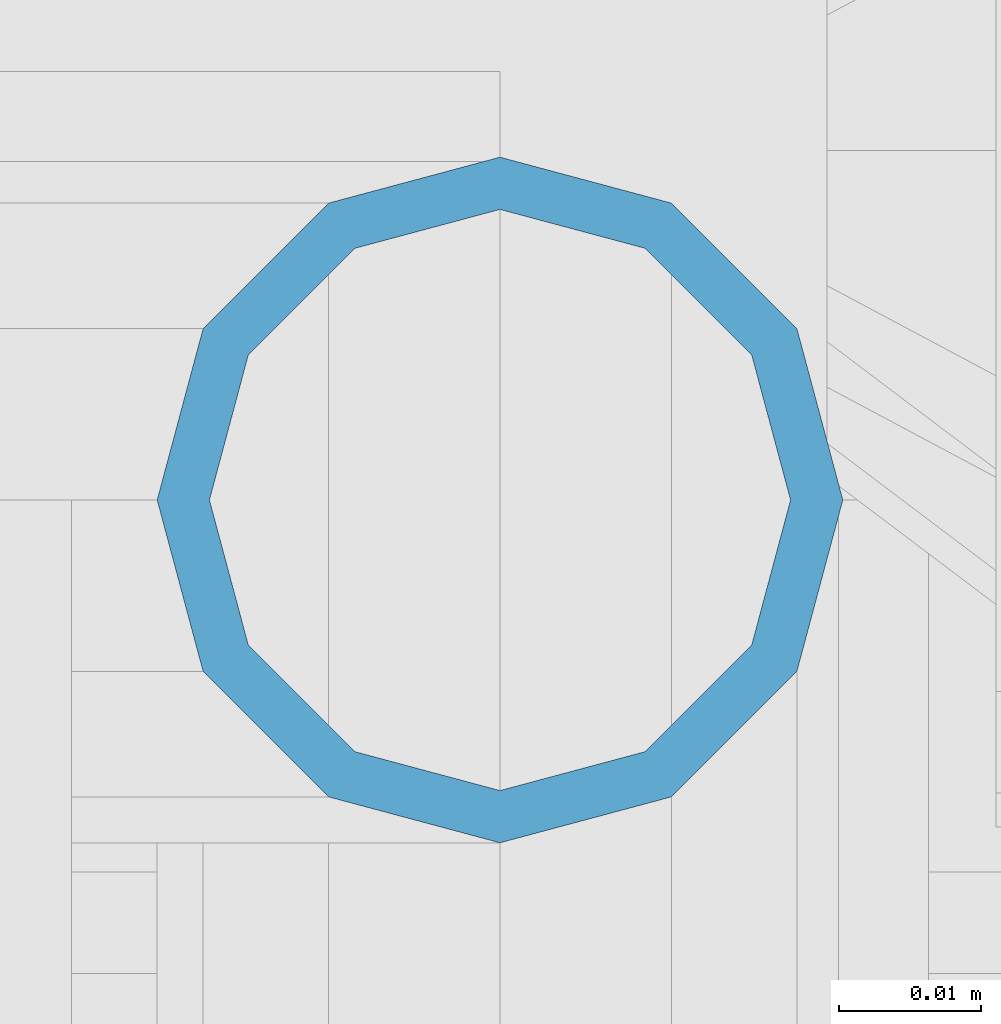
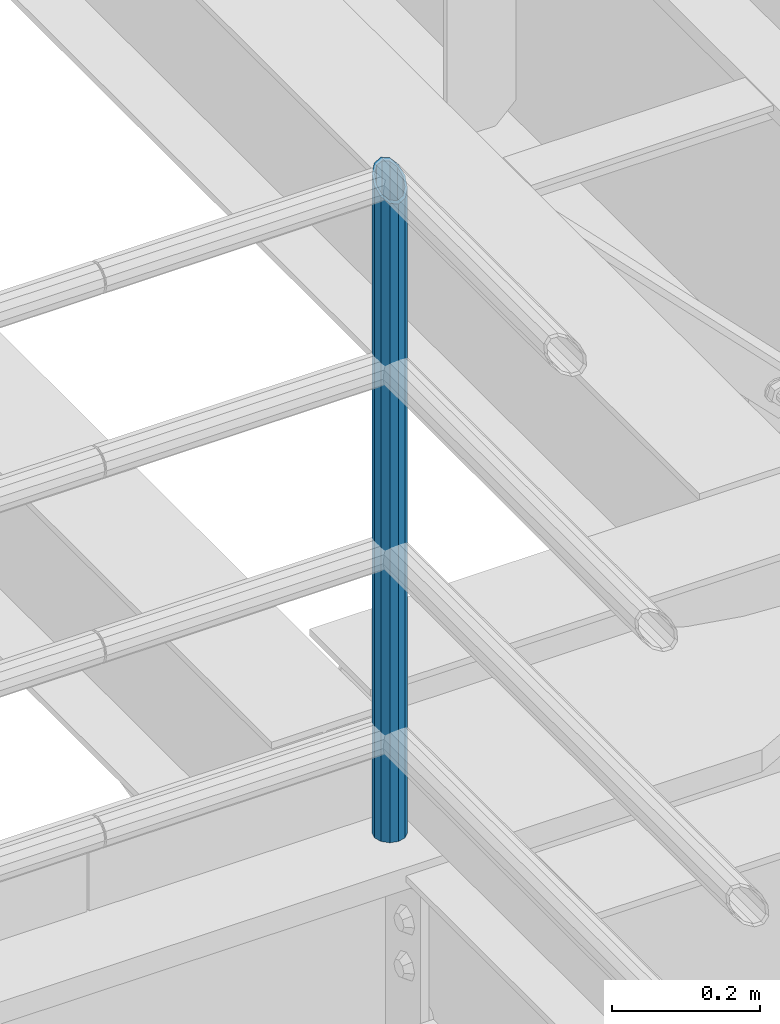
# One storey, part 646 of 1876: 1 column, 1 element without a shape of its own.
"""IFC2X3 building model written with IfcOpenShell, lengths in millimetres."""

from ifc_helpers import new_model, si_unit, frame, origin_with_axes, place, context, subcontext, project, spatial, faceted_brep, material, type_object, element, aggregate, save


model = new_model("IFC2X3")

# Units and contexts
model_context = context("Model", 3, precision=1e-05, world=origin_with_axes())
body_context = subcontext(model_context, "Body", "Model", "MODEL_VIEW")
ifc_project = project(units=[si_unit("LENGTHUNIT", "METRE", prefix="MILLI"), si_unit("AREAUNIT", "SQUARE_METRE"), si_unit("VOLUMEUNIT", "CUBIC_METRE"), si_unit("MASSUNIT", "GRAM", prefix="KILO"), si_unit("TIMEUNIT", "SECOND"), si_unit("PLANEANGLEUNIT", "RADIAN"), si_unit("SOLIDANGLEUNIT", "STERADIAN"), si_unit("THERMODYNAMICTEMPERATUREUNIT", "DEGREE_CELSIUS"), si_unit("LUMINOUSINTENSITYUNIT", "LUMEN")], contexts=[model_context])

# Site, building, storey
site_placement = place(None, origin_with_axes())
site = spatial("IfcSite", under=ifc_project, at=site_placement, CompositionType="ELEMENT")
building_placement = place(site_placement, origin_with_axes())
building = spatial("IfcBuilding", under=site, at=building_placement, Name="Undefined", CompositionType="ELEMENT")
storey_placement = place(building_placement, origin_with_axes())
storey = spatial("IfcBuildingStorey", under=building, at=storey_placement, Name="Undefined", CompositionType="ELEMENT", Elevation=0.0)

# Assembly, column
assembly_placement = place(storey_placement, origin_with_axes())
assembly = element("IfcElementAssembly", 1, at=assembly_placement, inside=storey, Name="RAIL", AssemblyPlace="NOTDEFINED", PredefinedType="RIGID_FRAME")
ifc_material = material()
column_type = type_object("IfcColumnType", Name="PIPE1-1/2SCH40", PredefinedType="NOTDEFINED")
column_placement = place(assembly_placement, frame((6197.6, -4654.55000114554, 5130.8), z_axis=(1.0, 0.0, 0.0), x_axis=(0.0, 0.0, 1.0)))
column = element("IfcColumn", 2, at=column_placement, type_object=column_type, material=ifc_material, Name="POST", ObjectType="PIPE1-1/2SCH40", context=body_context, shape_type="Brep", body=[
    faceted_brep([(0.0, -20.4469999999999, 0.0), (0.0, -17.7076214311803, 10.2235000000001), (1094.03262143118, -17.7076214311804, 10.2235000000001), (1096.772, -20.447, 0.0), (0.0, -10.2235000000001, 17.7076214311801), (1086.5485, -10.2235, 17.7076214311801), (-1.45519152283669e-11, 0.0, 20.4470000000001), (1076.325, 0.0, 20.4470000000001), (0.0, 10.2235000000001, 17.7076214311801), (1066.1015, 10.2235, 17.7076214311801), (0.0, 17.7076214311803, 10.2235000000001), (1058.61737856882, 17.7076214311804, 10.2235000000001), (0.0, 20.4469999999999, 0.0), (1055.878, 20.447, 0.0), (0.0, 17.7076214311803, -10.2235000000001), (1058.61737856882, 17.7076214311804, -10.2235000000001), (0.0, 10.2235000000001, -17.7076214311801), (1066.1015, 10.2235, -17.7076214311801), (-1.45519152283669e-11, 0.0, -20.4470000000001), (1076.325, 0.0, -20.4470000000001), (0.0, -10.2235000000001, -17.7076214311801), (1086.5485, -10.2235, -17.7076214311801), (0.0, -17.7076214311803, -10.2235000000001), (1094.03262143118, -17.7076214311804, -10.2235000000001), (0.0, -24.1299999999992, 0.0), (0.0, -20.8971929933184, -12.0649999999996), (1097.22219299332, -20.8971929933185, -12.0649999999996), (1100.455, -24.13, 0.0), (0.0, -12.0650000000001, -20.8971929933186), (1088.39, -12.065, -20.8971929933186), (-1.45519152283669e-11, 0.0, -24.130000000001), (1076.325, 0.0, -24.1300000000001), (0.0, 12.0650000000001, -20.8971929933186), (1064.26, 12.065, -20.8971929933186), (0.0, 20.8971929933184, -12.0649999999996), (1055.42780700668, 20.8971929933185, -12.0649999999996), (0.0, 24.1299999999992, 0.0), (1052.195, 24.13, 0.0), (0.0, 20.8971929933184, 12.0649999999996), (1055.42780700668, 20.8971929933185, 12.0649999999996), (0.0, 12.0650000000001, 20.8971929933186), (1064.26, 12.065, 20.8971929933186), (-1.45519152283669e-11, 0.0, 24.130000000001), (1076.325, 0.0, 24.1300000000001), (0.0, -12.0650000000001, 20.8971929933186), (1088.39, -12.065, 20.8971929933186), (0.0, -20.8971929933184, 12.0649999999996), (1097.22219299332, -20.8971929933185, 12.0649999999996)], [[[0, 1, 2, 3]], [[1, 4, 5, 2]], [[4, 6, 7, 5]], [[6, 8, 9, 7]], [[8, 10, 11, 9]], [[10, 12, 13, 11]], [[12, 14, 15, 13]], [[14, 16, 17, 15]], [[16, 18, 19, 17]], [[18, 20, 21, 19]], [[20, 22, 23, 21]], [[22, 0, 3, 23]], [[24, 25, 26, 27]], [[25, 28, 29, 26]], [[28, 30, 31, 29]], [[30, 32, 33, 31]], [[32, 34, 35, 33]], [[34, 36, 37, 35]], [[36, 38, 39, 37]], [[38, 40, 41, 39]], [[40, 42, 43, 41]], [[42, 44, 45, 43]], [[44, 46, 47, 45]], [[46, 24, 27, 47]], [[29, 31, 33, 35, 37, 39, 41, 43, 45, 47, 27, 26], [5, 7, 9, 11, 13, 15, 17, 19, 21, 23, 3, 2]], [[46, 44, 42, 40, 38, 36, 34, 32, 30, 28, 25, 24], [22, 20, 18, 16, 14, 12, 10, 8, 6, 4, 1, 0]]]),
])
aggregate(assembly, [column])

save(model, "model.ifc")
